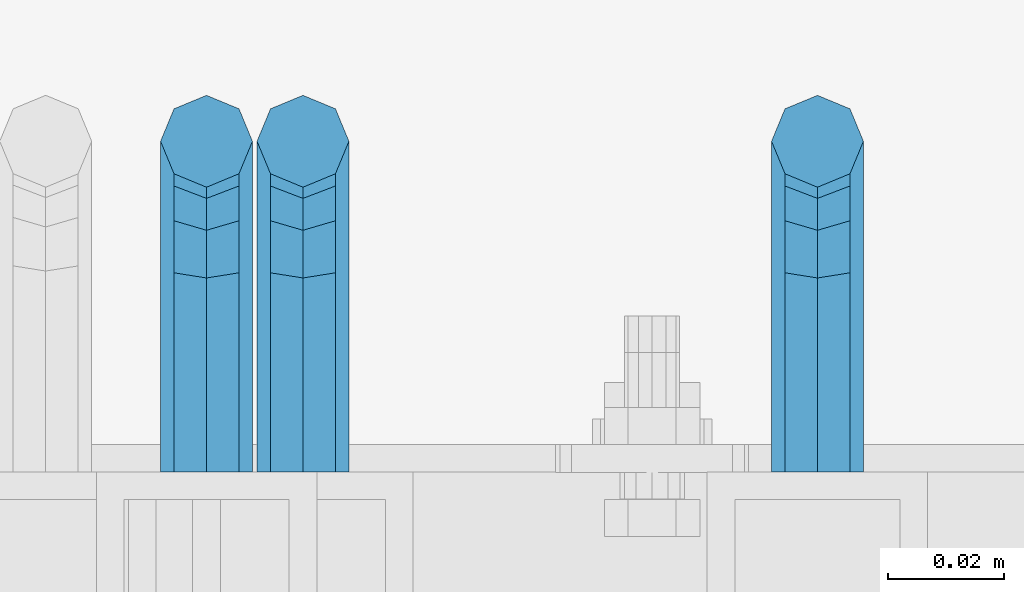
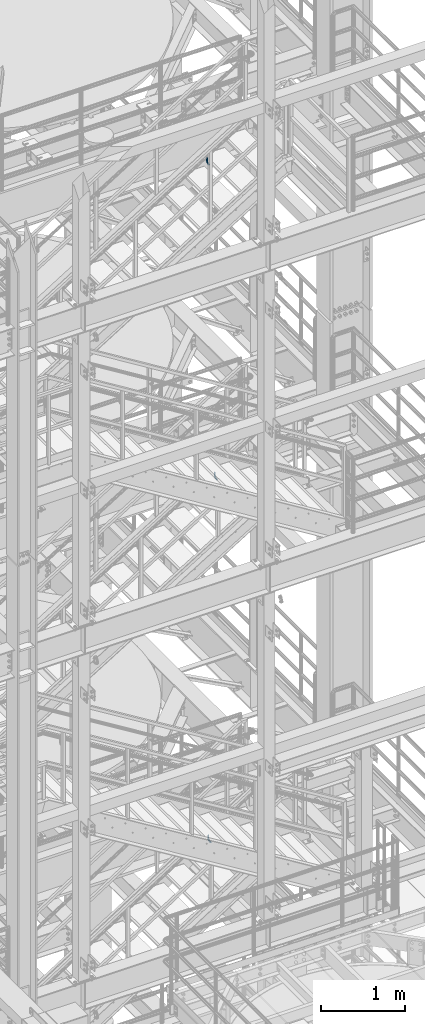
# One storey, part 1187 of 1876: 3 beams, 3 elements without a shape of their own.
"""IFC2X3 building model written with IfcOpenShell, lengths in millimetres."""

from ifc_helpers import new_model, si_unit, frame, origin_with_axes, place, context, subcontext, project, spatial, faceted_brep, material, type_object, element, aggregate, save


model = new_model("IFC2X3")

# Units and contexts
model_context = context("Model", 3, precision=1e-05, world=origin_with_axes())
body_context = subcontext(model_context, "Body", "Model", "MODEL_VIEW")
ifc_project = project(units=[si_unit("LENGTHUNIT", "METRE", prefix="MILLI"), si_unit("AREAUNIT", "SQUARE_METRE"), si_unit("VOLUMEUNIT", "CUBIC_METRE"), si_unit("MASSUNIT", "GRAM", prefix="KILO"), si_unit("TIMEUNIT", "SECOND"), si_unit("PLANEANGLEUNIT", "RADIAN"), si_unit("SOLIDANGLEUNIT", "STERADIAN"), si_unit("THERMODYNAMICTEMPERATUREUNIT", "DEGREE_CELSIUS"), si_unit("LUMINOUSINTENSITYUNIT", "LUMEN")], contexts=[model_context])

# Site, building, storey
site_placement = place(None, origin_with_axes())
site = spatial("IfcSite", under=ifc_project, at=site_placement, CompositionType="ELEMENT")
building_placement = place(site_placement, origin_with_axes())
building = spatial("IfcBuilding", under=site, at=building_placement, Name="Undefined", CompositionType="ELEMENT")
storey_placement = place(building_placement, origin_with_axes())
storey = spatial("IfcBuildingStorey", under=building, at=storey_placement, Name="Undefined", CompositionType="ELEMENT", Elevation=0.0)

# Assembly, beam
assembly_1_placement = place(storey_placement, origin_with_axes())
assembly_1 = element("IfcElementAssembly", 1, at=assembly_1_placement, inside=storey, Name="RAIL", AssemblyPlace="NOTDEFINED", PredefinedType="RIGID_FRAME")
ifc_material = material(Name="STEEL/A36")
beam_type = type_object("IfcBeamType", PredefinedType="NOTDEFINED")
beam_1_placement = place(assembly_1_placement, frame((5213.35000009587, -5715.00000114554, 13601.6614216208), z_axis=(1.0, 0.0, 0.0), x_axis=(0.0, 1.0, 0.0)))
beam_1 = element("IfcBeam", 2, at=beam_1_placement, type_object=beam_type, material=ifc_material, Name="BRACKET", context=body_context, shape_type="Brep", body=[
    faceted_brep([(0.0, -5.61266007566822, 5.61266007566883), (0.0, 0.0, 7.9375), (0.0, 5.61266007566822, 5.61266007566883), (0.0, 7.9375, 0.0), (0.0, 5.61266007566822, -5.61266007566883), (0.0, 0.0, -7.9375), (0.0, -5.61266007566822, -5.61266007566883), (0.0, -7.9375, 0.0), (23.8125, -5.61266007566883, -5.61266007566792), (23.8125, -7.9375, 0.0), (23.8125, -5.61266007566883, 5.61266007566792), (23.8125, 0.0, 7.9375), (23.8125, 5.61266007566883, 5.61266007566792), (23.8125, 7.9375, 0.0), (23.8125, 5.61266007566883, -5.61266007566792), (23.8125, 0.0, -7.9375), (36.5702095103998, 2.53766620105671, -7.9375), (38.7180815328556, -2.64775556579843, -5.61266007566792), (39.6077592547981, -4.79562758825341, 0.0), (38.7180815328556, -2.64775556579843, 5.61266007566792), (36.5702095103998, 2.53766620105671, 7.9375), (34.4223374879448, 7.72308796790821, 5.61266007566792), (33.5326597660023, 9.87095999036319, 0.0), (34.4223374879448, 7.72308796790821, -5.61266007566792), (43.4169233967659, 13.733078129113, -5.61266007566792), (47.3856733967659, 9.76432812911298, -7.9375), (41.773013321098, 15.3769882047818, 0.0), (43.4169233967659, 13.733078129113, 5.61266007566792), (47.3856733967659, 9.76432812911298, 7.9375), (51.3544233967659, 5.79557812911298, 5.61266007566792), (52.9983334724348, 4.15166805344415, 0.0), (51.3544233967659, 5.79557812911298, -5.61266007566792), (54.6123353248231, 20.5797920154801, -7.9375), (59.7977570916764, 18.4319199930251, -5.61266007566792), (49.4269135579698, 22.727664037935, -5.61266007566792), (47.2790415355148, 23.6173417598766, 0.0), (49.4269135579698, 22.727664037935, 5.61266007566792), (54.6123353248231, 20.5797920154801, 7.9375), (59.7977570916764, 18.4319199930251, 5.61266007566792), (61.9456291141314, 17.5422422710835, 0.0), (62.7626616015468, 33.3375015258789, -5.61266007566792), (65.0875015258789, 33.3375015258789, 0.0), (57.1500015258789, 33.3375015258789, -7.9375), (51.5373414502101, 33.3375015258789, -5.61266007566792), (49.2125015258789, 33.3375015258789, 0.0), (51.5373414502101, 33.3375015258789, 5.61266007566792), (57.1500015258789, 33.3375015258789, 7.9375), (62.7626616015468, 33.3375015258789, 5.61266007566792), (65.0875015258789, 66.6490606416592, 0.0), (62.7626616015468, 70.1016967070464, 5.61266007566792), (57.1500015258789, 71.5318253912683, 7.9375), (51.537341450211, 70.1016967070464, 5.61266007566792), (49.2125015258789, 66.6490606416592, 0.0), (51.537341450211, 63.1964245762738, -5.61266007566792), (57.1500015258789, 61.7662958920519, -7.9375), (62.7626616015468, 63.1964245762738, -5.61266007566792)], [[[0, 1, 2, 3, 4, 5, 6, 7]], [[7, 6, 8, 9]], [[0, 7, 9, 10]], [[1, 0, 10, 11]], [[2, 1, 11, 12]], [[3, 2, 12, 13]], [[4, 3, 13, 14]], [[5, 4, 14, 15]], [[6, 5, 15, 8]], [[8, 15, 16, 17]], [[9, 8, 17, 18]], [[10, 9, 18, 19]], [[11, 10, 19, 20]], [[12, 11, 20, 21]], [[13, 12, 21, 22]], [[14, 13, 22, 23]], [[15, 14, 23, 16]], [[23, 24, 25, 16]], [[22, 26, 24, 23]], [[21, 27, 26, 22]], [[20, 28, 27, 21]], [[19, 29, 28, 20]], [[18, 30, 29, 19]], [[17, 31, 30, 18]], [[16, 25, 31, 17]], [[25, 32, 33, 31]], [[24, 34, 32, 25]], [[26, 35, 34, 24]], [[27, 36, 35, 26]], [[28, 37, 36, 27]], [[29, 38, 37, 28]], [[30, 39, 38, 29]], [[31, 33, 39, 30]], [[33, 40, 41, 39]], [[32, 42, 40, 33]], [[34, 43, 42, 32]], [[35, 44, 43, 34]], [[36, 45, 44, 35]], [[37, 46, 45, 36]], [[38, 47, 46, 37]], [[39, 41, 47, 38]], [[47, 41, 48, 49]], [[46, 47, 49, 50]], [[45, 46, 50, 51]], [[44, 45, 51, 52]], [[43, 44, 52, 53]], [[42, 43, 53, 54]], [[40, 42, 54, 55]], [[41, 40, 55, 48]], [[54, 53, 52, 51, 50, 49, 48, 55]]]),
])
aggregate(assembly_1, [beam_1])

assembly_2_placement = place(storey_placement, origin_with_axes())
assembly_2 = element("IfcElementAssembly", 3, at=assembly_2_placement, inside=storey, Name="RAIL", AssemblyPlace="NOTDEFINED", PredefinedType="RIGID_FRAME")
beam_2_placement = place(assembly_2_placement, frame((5107.78124790345, -5715.00000114554, 18205.9952849721), z_axis=(1.0, 0.0, 0.0), x_axis=(0.0, 1.0, 0.0)))
beam_2 = element("IfcBeam", 4, at=beam_2_placement, type_object=beam_type, material=ifc_material, Name="BRACKET", context=body_context, shape_type="Brep", body=[
    faceted_brep([(0.0, -5.61266007566822, 5.61266007566883), (0.0, 0.0, 7.9375), (0.0, 5.61266007566822, 5.61266007566883), (0.0, 7.9375, 0.0), (0.0, 5.61266007566822, -5.61266007566883), (0.0, 0.0, -7.9375), (0.0, -5.61266007566822, -5.61266007566883), (0.0, -7.9375, 0.0), (23.8125, -5.61266007566883, -5.61266007566792), (23.8125, -7.9375, 0.0), (23.8125, -5.61266007566883, 5.61266007566792), (23.8125, 0.0, 7.9375), (23.8125, 5.61266007566883, 5.61266007566792), (23.8125, 7.9375, 0.0), (23.8125, 5.61266007566883, -5.61266007566792), (23.8125, 0.0, -7.9375), (36.5702095103998, 2.53766620105671, -7.9375), (38.7180815328556, -2.64775556579843, -5.61266007566792), (39.6077592547981, -4.79562758825341, 0.0), (38.7180815328556, -2.64775556579843, 5.61266007566792), (36.5702095103998, 2.53766620105671, 7.9375), (34.4223374879448, 7.72308796790821, 5.61266007566792), (33.5326597660023, 9.87095999036319, 0.0), (34.4223374879448, 7.72308796790821, -5.61266007566792), (43.4169233967659, 13.733078129113, -5.61266007566792), (47.3856733967659, 9.76432812911298, -7.9375), (41.773013321098, 15.3769882047818, 0.0), (43.4169233967659, 13.733078129113, 5.61266007566792), (47.3856733967659, 9.76432812911298, 7.9375), (51.3544233967659, 5.79557812911298, 5.61266007566792), (52.9983334724348, 4.15166805344415, 0.0), (51.3544233967659, 5.79557812911298, -5.61266007566792), (54.6123353248231, 20.5797920154801, -7.9375), (59.7977570916764, 18.4319199930251, -5.61266007566792), (49.4269135579698, 22.727664037935, -5.61266007566792), (47.2790415355148, 23.6173417598766, 0.0), (49.4269135579698, 22.727664037935, 5.61266007566792), (54.6123353248231, 20.5797920154801, 7.9375), (59.7977570916764, 18.4319199930251, 5.61266007566792), (61.9456291141314, 17.5422422710835, 0.0), (62.7626616015468, 33.3375015258789, -5.61266007566792), (65.0875015258789, 33.3375015258789, 0.0), (57.1500015258789, 33.3375015258789, -7.9375), (51.5373414502101, 33.3375015258789, -5.61266007566792), (49.2125015258789, 33.3375015258789, 0.0), (51.5373414502101, 33.3375015258789, 5.61266007566792), (57.1500015258789, 33.3375015258789, 7.9375), (62.7626616015468, 33.3375015258789, 5.61266007566792), (65.0875015258789, 66.4903820289292, 0.0), (62.7626616015468, 69.9676002640044, 5.61266007566837), (57.1500015258789, 71.4079051966655, 7.9375), (51.537341450211, 69.9676002640044, 5.61266007566837), (49.2125015258789, 66.4903820289292, 0.0), (51.537341450211, 63.0131928592527, -5.61266007566837), (57.1500015258789, 61.5728879265953, -7.9375), (62.7626616015468, 63.0131928592527, -5.61266007566837)], [[[0, 1, 2, 3, 4, 5, 6, 7]], [[7, 6, 8, 9]], [[0, 7, 9, 10]], [[1, 0, 10, 11]], [[2, 1, 11, 12]], [[3, 2, 12, 13]], [[4, 3, 13, 14]], [[5, 4, 14, 15]], [[6, 5, 15, 8]], [[8, 15, 16, 17]], [[9, 8, 17, 18]], [[10, 9, 18, 19]], [[11, 10, 19, 20]], [[12, 11, 20, 21]], [[13, 12, 21, 22]], [[14, 13, 22, 23]], [[15, 14, 23, 16]], [[23, 24, 25, 16]], [[22, 26, 24, 23]], [[21, 27, 26, 22]], [[20, 28, 27, 21]], [[19, 29, 28, 20]], [[18, 30, 29, 19]], [[17, 31, 30, 18]], [[16, 25, 31, 17]], [[25, 32, 33, 31]], [[24, 34, 32, 25]], [[26, 35, 34, 24]], [[27, 36, 35, 26]], [[28, 37, 36, 27]], [[29, 38, 37, 28]], [[30, 39, 38, 29]], [[31, 33, 39, 30]], [[33, 40, 41, 39]], [[32, 42, 40, 33]], [[34, 43, 42, 32]], [[35, 44, 43, 34]], [[36, 45, 44, 35]], [[37, 46, 45, 36]], [[38, 47, 46, 37]], [[39, 41, 47, 38]], [[47, 41, 48, 49]], [[46, 47, 49, 50]], [[45, 46, 50, 51]], [[44, 45, 51, 52]], [[43, 44, 52, 53]], [[42, 43, 53, 54]], [[40, 42, 54, 55]], [[41, 40, 55, 48]], [[54, 53, 52, 51, 50, 49, 48, 55]]]),
])
aggregate(assembly_2, [beam_2])

assembly_3_placement = place(storey_placement, origin_with_axes())
assembly_3 = element("IfcElementAssembly", 5, at=assembly_3_placement, inside=storey, Name="RAIL", AssemblyPlace="NOTDEFINED", PredefinedType="RIGID_FRAME")
beam_3_placement = place(assembly_3_placement, frame((5124.44999535449, -5715.00000114554, 8370.16608177382), z_axis=(1.0, 0.0, 0.0), x_axis=(0.0, 1.0, 0.0)))
beam_3 = element("IfcBeam", 6, at=beam_3_placement, type_object=beam_type, material=ifc_material, Name="BRACKET", context=body_context, shape_type="Brep", body=[
    faceted_brep([(0.0, -5.61266007566822, 5.61266007566883), (0.0, 0.0, 7.9375), (0.0, 5.61266007566822, 5.61266007566883), (0.0, 7.9375, 0.0), (0.0, 5.61266007566822, -5.61266007566883), (0.0, 0.0, -7.9375), (0.0, -5.61266007566822, -5.61266007566883), (0.0, -7.9375, 0.0), (23.8125, -5.61266007566883, -5.61266007566792), (23.8125, -7.9375, 0.0), (23.8125, -5.61266007566883, 5.61266007566792), (23.8125, 0.0, 7.9375), (23.8125, 5.61266007566883, 5.61266007566792), (23.8125, 7.9375, 0.0), (23.8125, 5.61266007566883, -5.61266007566792), (23.8125, 0.0, -7.9375), (36.5702095103998, 2.53766620105671, -7.9375), (38.7180815328556, -2.64775556579843, -5.61266007566792), (39.6077592547981, -4.79562758825341, 0.0), (38.7180815328556, -2.64775556579843, 5.61266007566792), (36.5702095103998, 2.53766620105671, 7.9375), (34.4223374879448, 7.72308796790821, 5.61266007566792), (33.5326597660023, 9.87095999036319, 0.0), (34.4223374879448, 7.72308796790821, -5.61266007566792), (43.4169233967659, 13.733078129113, -5.61266007566792), (47.3856733967659, 9.76432812911298, -7.9375), (41.773013321098, 15.3769882047818, 0.0), (43.4169233967659, 13.733078129113, 5.61266007566792), (47.3856733967659, 9.76432812911298, 7.9375), (51.3544233967659, 5.79557812911298, 5.61266007566792), (52.9983334724348, 4.15166805344415, 0.0), (51.3544233967659, 5.79557812911298, -5.61266007566792), (54.6123353248231, 20.5797920154801, -7.9375), (59.7977570916764, 18.4319199930251, -5.61266007566792), (49.4269135579698, 22.727664037935, -5.61266007566792), (47.2790415355148, 23.6173417598766, 0.0), (49.4269135579698, 22.727664037935, 5.61266007566792), (54.6123353248231, 20.5797920154801, 7.9375), (59.7977570916764, 18.4319199930251, 5.61266007566792), (61.9456291141314, 17.5422422710835, 0.0), (62.7626616015468, 33.3375015258789, -5.61266007566792), (65.0875015258789, 33.3375015258789, 0.0), (57.1500015258789, 33.3375015258789, -7.9375), (51.5373414502101, 33.3375015258789, -5.61266007566792), (49.2125015258789, 33.3375015258789, 0.0), (51.5373414502101, 33.3375015258789, 5.61266007566792), (57.1500015258789, 33.3375015258789, 7.9375), (62.7626616015468, 33.3375015258789, 5.61266007566792), (65.0875015258789, 66.3198431774908, 4.46561898570508e-10), (62.7626616015423, 69.8915357799633, 5.61266007614358), (57.1500015258725, 71.370979296531, 7.93750000048021), (51.5373414502064, 69.891535779956, 5.61266007613449), (49.2125015258789, 66.3198431774854, 4.38376446254551e-10), (51.5373414502164, 62.7481505750166, -5.61266007525228), (57.150001525888, 61.2687070584507, -7.937499999588), (62.7626616015532, 62.7481505750256, -5.61266007523955)], [[[0, 1, 2, 3, 4, 5, 6, 7]], [[7, 6, 8, 9]], [[0, 7, 9, 10]], [[1, 0, 10, 11]], [[2, 1, 11, 12]], [[3, 2, 12, 13]], [[4, 3, 13, 14]], [[5, 4, 14, 15]], [[6, 5, 15, 8]], [[8, 15, 16, 17]], [[9, 8, 17, 18]], [[10, 9, 18, 19]], [[11, 10, 19, 20]], [[12, 11, 20, 21]], [[13, 12, 21, 22]], [[14, 13, 22, 23]], [[15, 14, 23, 16]], [[23, 24, 25, 16]], [[22, 26, 24, 23]], [[21, 27, 26, 22]], [[20, 28, 27, 21]], [[19, 29, 28, 20]], [[18, 30, 29, 19]], [[17, 31, 30, 18]], [[16, 25, 31, 17]], [[25, 32, 33, 31]], [[24, 34, 32, 25]], [[26, 35, 34, 24]], [[27, 36, 35, 26]], [[28, 37, 36, 27]], [[29, 38, 37, 28]], [[30, 39, 38, 29]], [[31, 33, 39, 30]], [[33, 40, 41, 39]], [[32, 42, 40, 33]], [[34, 43, 42, 32]], [[35, 44, 43, 34]], [[36, 45, 44, 35]], [[37, 46, 45, 36]], [[38, 47, 46, 37]], [[39, 41, 47, 38]], [[47, 41, 48, 49]], [[46, 47, 49, 50]], [[45, 46, 50, 51]], [[44, 45, 51, 52]], [[43, 44, 52, 53]], [[42, 43, 53, 54]], [[40, 42, 54, 55]], [[41, 40, 55, 48]], [[54, 53, 52, 51, 50, 49, 48, 55]]]),
])
aggregate(assembly_3, [beam_3])

save(model, "model.ifc")
